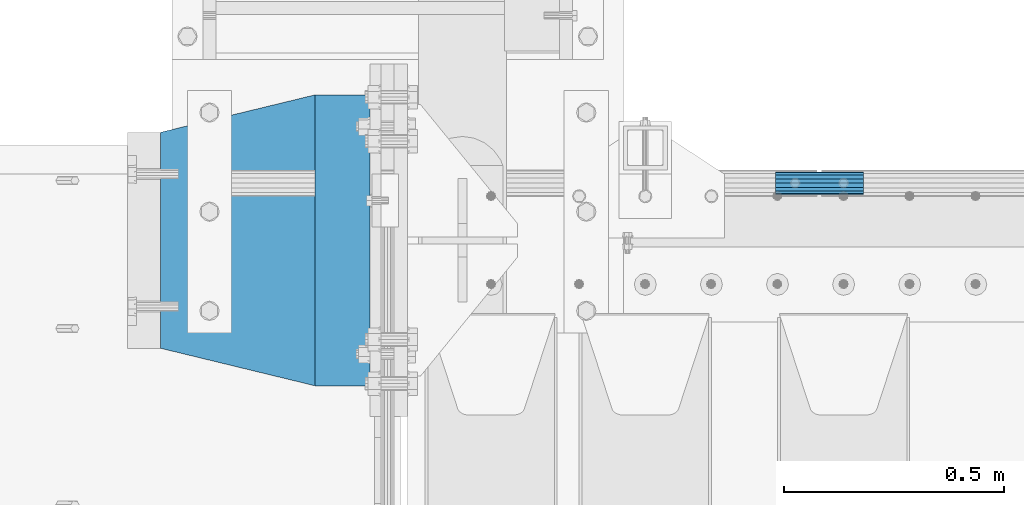
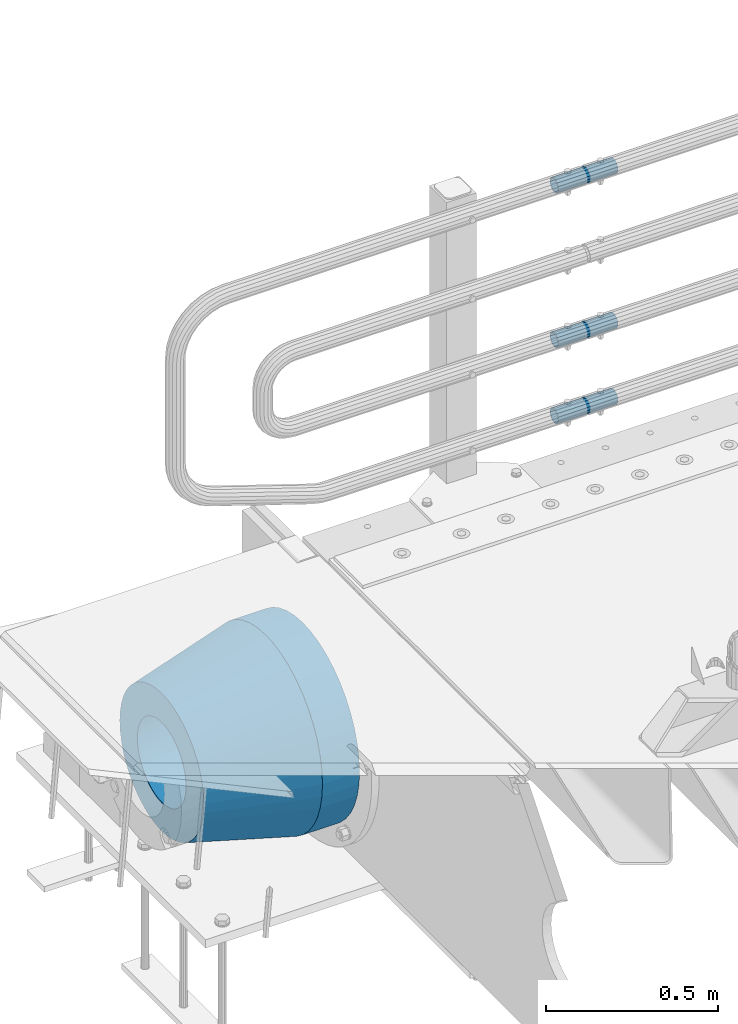
# One storey, part 151 of 240: 5 beams.
"""IFC2X3 building model written with IfcOpenShell, lengths in millimetres."""

from ifc_helpers import new_model, si_unit, frame, origin_with_axes, place, context, subcontext, project, spatial, faceted_brep, material, type_object, element, save


model = new_model("IFC2X3")

# Units and contexts
model_context = context("Model", 3, precision=1e-05, world=origin_with_axes())
body_context = subcontext(model_context, "Body", "Model", "MODEL_VIEW")
ifc_project = project(units=[si_unit("LENGTHUNIT", "METRE", prefix="MILLI"), si_unit("AREAUNIT", "SQUARE_METRE"), si_unit("VOLUMEUNIT", "CUBIC_METRE"), si_unit("MASSUNIT", "GRAM", prefix="KILO"), si_unit("TIMEUNIT", "SECOND"), si_unit("PLANEANGLEUNIT", "RADIAN"), si_unit("SOLIDANGLEUNIT", "STERADIAN"), si_unit("THERMODYNAMICTEMPERATUREUNIT", "DEGREE_CELSIUS"), si_unit("LUMINOUSINTENSITYUNIT", "LUMEN")], contexts=[model_context])

# Site, building, storey
site_placement = place(None, origin_with_axes())
site = spatial("IfcSite", under=ifc_project, at=site_placement, CompositionType="ELEMENT")
building_placement = place(site_placement, origin_with_axes())
building = spatial("IfcBuilding", under=site, at=building_placement, Name="Standard", CompositionType="ELEMENT")
storey_placement = place(building_placement, origin_with_axes())
storey = spatial("IfcBuildingStorey", under=building, at=storey_placement, Name="Undefined", CompositionType="ELEMENT", Elevation=0.0)

# Beams
ifc_material_1 = material()
beam_type_1 = type_object("IfcBeamType", PredefinedType="NOTDEFINED")
beam_1_placement = place(storey_placement, frame((43294.9975029999, 36129.8500000004, 149.849999999747), z_axis=(0.0, 0.0, 1.0), x_axis=(1.0, 0.0, 0.0)))
element("IfcBeam", 1, at=beam_1_placement, inside=storey, type_object=beam_type_1, material=ifc_material_1, context=body_context, shape_type="Brep", body=[
    faceted_brep([(0.0, -21.9000000000015, 0.0), (0.0, -20.232961761998, 8.38076716879547), (200.0, -20.232961761998, 8.38076716879547), (200.0, -21.9000000000015, 0.0), (0.0, -15.4856385079838, 15.4856385079854), (200.0, -15.4856385079838, 15.4856385079854), (0.0, -8.38076716879732, 20.2329617619972), (200.0, -8.38076716879732, 20.2329617619972), (0.0, 0.0, 21.9), (200.0, 0.0, 21.9), (0.0, 8.38076716879732, 20.2329617619972), (200.0, 8.38076716879732, 20.2329617619972), (0.0, 15.4856385079838, 15.4856385079854), (200.0, 15.4856385079838, 15.4856385079854), (0.0, 20.232961761998, 8.38076716879547), (200.0, 20.232961761998, 8.38076716879547), (0.0, 21.9000000000015, 0.0), (200.0, 21.9000000000015, 0.0), (0.0, 20.232961761998, -8.38076716879547), (200.0, 20.232961761998, -8.38076716879547), (0.0, 15.4856385079838, -15.4856385079854), (200.0, 15.4856385079838, -15.4856385079854), (0.0, 8.38076716879732, -20.2329617619972), (200.0, 8.38076716879732, -20.2329617619972), (0.0, 0.0, -21.9), (200.0, 0.0, -21.9), (0.0, -8.38076716879732, -20.2329617619972), (200.0, -8.38076716879732, -20.2329617619972), (0.0, -15.4856385079838, -15.4856385079854), (200.0, -15.4856385079838, -15.4856385079854), (0.0, -20.232961761998, -8.38076716879547), (200.0, -20.232961761998, -8.38076716879547), (0.0, -25.5, 0.0), (0.0, -23.5589280790373, -9.7584275253098), (200.0, -23.5589280790373, -9.7584275253098), (200.0, -25.5, 0.0), (0.0, -18.0312229202536, -18.031222920257), (200.0, -18.0312229202536, -18.031222920257), (0.0, -9.75842752531025, -23.5589280790378), (200.0, -9.75842752531025, -23.5589280790378), (0.0, 0.0, -25.5), (200.0, 0.0, -25.5), (0.0, 9.75842752531025, -23.5589280790378), (200.0, 9.75842752531025, -23.5589280790378), (0.0, 18.0312229202536, -18.031222920257), (200.0, 18.0312229202536, -18.031222920257), (0.0, 23.5589280790373, -9.7584275253098), (200.0, 23.5589280790373, -9.7584275253098), (0.0, 25.5, 0.0), (200.0, 25.5, 0.0), (0.0, 23.5589280790373, 9.7584275253098), (200.0, 23.5589280790373, 9.7584275253098), (0.0, 18.0312229202536, 18.031222920257), (200.0, 18.0312229202536, 18.031222920257), (0.0, 9.75842752531025, 23.5589280790378), (200.0, 9.75842752531025, 23.5589280790378), (0.0, 0.0, 25.5), (200.0, 0.0, 25.5), (0.0, -9.75842752531025, 23.5589280790378), (200.0, -9.75842752531025, 23.5589280790378), (0.0, -18.0312229202536, 18.031222920257), (200.0, -18.0312229202536, 18.031222920257), (0.0, -23.5589280790373, 9.7584275253098), (200.0, -23.5589280790373, 9.7584275253098)], [[[0, 1, 2, 3]], [[1, 4, 5, 2]], [[4, 6, 7, 5]], [[6, 8, 9, 7]], [[8, 10, 11, 9]], [[10, 12, 13, 11]], [[12, 14, 15, 13]], [[14, 16, 17, 15]], [[16, 18, 19, 17]], [[18, 20, 21, 19]], [[20, 22, 23, 21]], [[22, 24, 25, 23]], [[24, 26, 27, 25]], [[26, 28, 29, 27]], [[28, 30, 31, 29]], [[30, 0, 3, 31]], [[32, 33, 34, 35]], [[33, 36, 37, 34]], [[36, 38, 39, 37]], [[38, 40, 41, 39]], [[40, 42, 43, 41]], [[42, 44, 45, 43]], [[44, 46, 47, 45]], [[46, 48, 49, 47]], [[48, 50, 51, 49]], [[50, 52, 53, 51]], [[52, 54, 55, 53]], [[54, 56, 57, 55]], [[56, 58, 59, 57]], [[58, 60, 61, 59]], [[60, 62, 63, 61]], [[62, 32, 35, 63]], [[37, 39, 41, 43, 45, 47, 49, 51, 53, 55, 57, 59, 61, 63, 35, 34], [5, 7, 9, 11, 13, 15, 17, 19, 21, 23, 25, 27, 29, 31, 3, 2]], [[62, 60, 58, 56, 54, 52, 50, 48, 46, 44, 42, 40, 38, 36, 33, 32], [30, 28, 26, 24, 22, 20, 18, 16, 14, 12, 10, 8, 6, 4, 1, 0]]]),
])
beam_2_placement = place(storey_placement, frame((43294.9975029999, 36129.8500000004, 420.149999999747), z_axis=(0.0, 0.0, 1.0), x_axis=(1.0, 0.0, 0.0)))
element("IfcBeam", 2, at=beam_2_placement, inside=storey, type_object=beam_type_1, material=ifc_material_1, context=body_context, shape_type="Brep", body=[
    faceted_brep([(0.0, -21.9000000000015, 0.0), (0.0, -20.232961761998, 8.38076716879547), (200.0, -20.232961761998, 8.38076716879547), (200.0, -21.9000000000015, 0.0), (0.0, -15.4856385079838, 15.4856385079854), (200.0, -15.4856385079838, 15.4856385079854), (0.0, -8.38076716879732, 20.2329617619972), (200.0, -8.38076716879732, 20.2329617619972), (0.0, 0.0, 21.9), (200.0, 0.0, 21.9), (0.0, 8.38076716879732, 20.2329617619972), (200.0, 8.38076716879732, 20.2329617619972), (0.0, 15.4856385079838, 15.4856385079854), (200.0, 15.4856385079838, 15.4856385079854), (0.0, 20.232961761998, 8.38076716879547), (200.0, 20.232961761998, 8.38076716879547), (0.0, 21.9000000000015, 0.0), (200.0, 21.9000000000015, 0.0), (0.0, 20.232961761998, -8.38076716879547), (200.0, 20.232961761998, -8.38076716879547), (0.0, 15.4856385079838, -15.4856385079854), (200.0, 15.4856385079838, -15.4856385079854), (0.0, 8.38076716879732, -20.2329617619972), (200.0, 8.38076716879732, -20.2329617619972), (0.0, 0.0, -21.9), (200.0, 0.0, -21.9), (0.0, -8.38076716879732, -20.2329617619972), (200.0, -8.38076716879732, -20.2329617619972), (0.0, -15.4856385079838, -15.4856385079854), (200.0, -15.4856385079838, -15.4856385079854), (0.0, -20.232961761998, -8.38076716879547), (200.0, -20.232961761998, -8.38076716879547), (0.0, -25.5, 0.0), (0.0, -23.5589280790373, -9.7584275253098), (200.0, -23.5589280790373, -9.7584275253098), (200.0, -25.5, 0.0), (0.0, -18.0312229202536, -18.031222920257), (200.0, -18.0312229202536, -18.031222920257), (0.0, -9.75842752531025, -23.5589280790378), (200.0, -9.75842752531025, -23.5589280790378), (0.0, 0.0, -25.5), (200.0, 0.0, -25.5), (0.0, 9.75842752531025, -23.5589280790378), (200.0, 9.75842752531025, -23.5589280790378), (0.0, 18.0312229202536, -18.031222920257), (200.0, 18.0312229202536, -18.031222920257), (0.0, 23.5589280790373, -9.7584275253098), (200.0, 23.5589280790373, -9.7584275253098), (0.0, 25.5, 0.0), (200.0, 25.5, 0.0), (0.0, 23.5589280790373, 9.7584275253098), (200.0, 23.5589280790373, 9.7584275253098), (0.0, 18.0312229202536, 18.031222920257), (200.0, 18.0312229202536, 18.031222920257), (0.0, 9.75842752531025, 23.5589280790378), (200.0, 9.75842752531025, 23.5589280790378), (0.0, 0.0, 25.5), (200.0, 0.0, 25.5), (0.0, -9.75842752531025, 23.5589280790378), (200.0, -9.75842752531025, 23.5589280790378), (0.0, -18.0312229202536, 18.031222920257), (200.0, -18.0312229202536, 18.031222920257), (0.0, -23.5589280790373, 9.7584275253098), (200.0, -23.5589280790373, 9.7584275253098)], [[[0, 1, 2, 3]], [[1, 4, 5, 2]], [[4, 6, 7, 5]], [[6, 8, 9, 7]], [[8, 10, 11, 9]], [[10, 12, 13, 11]], [[12, 14, 15, 13]], [[14, 16, 17, 15]], [[16, 18, 19, 17]], [[18, 20, 21, 19]], [[20, 22, 23, 21]], [[22, 24, 25, 23]], [[24, 26, 27, 25]], [[26, 28, 29, 27]], [[28, 30, 31, 29]], [[30, 0, 3, 31]], [[32, 33, 34, 35]], [[33, 36, 37, 34]], [[36, 38, 39, 37]], [[38, 40, 41, 39]], [[40, 42, 43, 41]], [[42, 44, 45, 43]], [[44, 46, 47, 45]], [[46, 48, 49, 47]], [[48, 50, 51, 49]], [[50, 52, 53, 51]], [[52, 54, 55, 53]], [[54, 56, 57, 55]], [[56, 58, 59, 57]], [[58, 60, 61, 59]], [[60, 62, 63, 61]], [[62, 32, 35, 63]], [[37, 39, 41, 43, 45, 47, 49, 51, 53, 55, 57, 59, 61, 63, 35, 34], [5, 7, 9, 11, 13, 15, 17, 19, 21, 23, 25, 27, 29, 31, 3, 2]], [[62, 60, 58, 56, 54, 52, 50, 48, 46, 44, 42, 40, 38, 36, 33, 32], [30, 28, 26, 24, 22, 20, 18, 16, 14, 12, 10, 8, 6, 4, 1, 0]]]),
])
beam_3_placement = place(storey_placement, frame((43294.9975029999, 36129.8500000004, 969.849999999747), z_axis=(0.0, 0.0, 1.0), x_axis=(1.0, 0.0, 0.0)))
element("IfcBeam", 3, at=beam_3_placement, inside=storey, type_object=beam_type_1, material=ifc_material_1, context=body_context, shape_type="Brep", body=[
    faceted_brep([(0.0, -21.9000000000015, 0.0), (0.0, -20.232961761998, 8.38076716879547), (200.0, -20.232961761998, 8.38076716879547), (200.0, -21.9000000000015, 0.0), (0.0, -15.4856385079838, 15.4856385079854), (200.0, -15.4856385079838, 15.4856385079854), (0.0, -8.38076716879732, 20.2329617619972), (200.0, -8.38076716879732, 20.2329617619972), (0.0, 0.0, 21.9), (200.0, 0.0, 21.9), (0.0, 8.38076716879732, 20.2329617619972), (200.0, 8.38076716879732, 20.2329617619972), (0.0, 15.4856385079838, 15.4856385079854), (200.0, 15.4856385079838, 15.4856385079854), (0.0, 20.232961761998, 8.38076716879547), (200.0, 20.232961761998, 8.38076716879547), (0.0, 21.9000000000015, 0.0), (200.0, 21.9000000000015, 0.0), (0.0, 20.232961761998, -8.38076716879547), (200.0, 20.232961761998, -8.38076716879547), (0.0, 15.4856385079838, -15.4856385079854), (200.0, 15.4856385079838, -15.4856385079854), (0.0, 8.38076716879732, -20.2329617619972), (200.0, 8.38076716879732, -20.2329617619972), (0.0, 0.0, -21.9), (200.0, 0.0, -21.9), (0.0, -8.38076716879732, -20.2329617619972), (200.0, -8.38076716879732, -20.2329617619972), (0.0, -15.4856385079838, -15.4856385079854), (200.0, -15.4856385079838, -15.4856385079854), (0.0, -20.232961761998, -8.38076716879547), (200.0, -20.232961761998, -8.38076716879547), (0.0, -25.5, 0.0), (0.0, -23.5589280790373, -9.7584275253098), (200.0, -23.5589280790373, -9.7584275253098), (200.0, -25.5, 0.0), (0.0, -18.0312229202536, -18.031222920257), (200.0, -18.0312229202536, -18.031222920257), (0.0, -9.75842752531025, -23.5589280790378), (200.0, -9.75842752531025, -23.5589280790378), (0.0, 0.0, -25.5), (200.0, 0.0, -25.5), (0.0, 9.75842752531025, -23.5589280790378), (200.0, 9.75842752531025, -23.5589280790378), (0.0, 18.0312229202536, -18.031222920257), (200.0, 18.0312229202536, -18.031222920257), (0.0, 23.5589280790373, -9.7584275253098), (200.0, 23.5589280790373, -9.7584275253098), (0.0, 25.5, 0.0), (200.0, 25.5, 0.0), (0.0, 23.5589280790373, 9.7584275253098), (200.0, 23.5589280790373, 9.7584275253098), (0.0, 18.0312229202536, 18.031222920257), (200.0, 18.0312229202536, 18.031222920257), (0.0, 9.75842752531025, 23.5589280790378), (200.0, 9.75842752531025, 23.5589280790378), (0.0, 0.0, 25.5), (200.0, 0.0, 25.5), (0.0, -9.75842752531025, 23.5589280790378), (200.0, -9.75842752531025, 23.5589280790378), (0.0, -18.0312229202536, 18.031222920257), (200.0, -18.0312229202536, 18.031222920257), (0.0, -23.5589280790373, 9.7584275253098), (200.0, -23.5589280790373, 9.7584275253098)], [[[0, 1, 2, 3]], [[1, 4, 5, 2]], [[4, 6, 7, 5]], [[6, 8, 9, 7]], [[8, 10, 11, 9]], [[10, 12, 13, 11]], [[12, 14, 15, 13]], [[14, 16, 17, 15]], [[16, 18, 19, 17]], [[18, 20, 21, 19]], [[20, 22, 23, 21]], [[22, 24, 25, 23]], [[24, 26, 27, 25]], [[26, 28, 29, 27]], [[28, 30, 31, 29]], [[30, 0, 3, 31]], [[32, 33, 34, 35]], [[33, 36, 37, 34]], [[36, 38, 39, 37]], [[38, 40, 41, 39]], [[40, 42, 43, 41]], [[42, 44, 45, 43]], [[44, 46, 47, 45]], [[46, 48, 49, 47]], [[48, 50, 51, 49]], [[50, 52, 53, 51]], [[52, 54, 55, 53]], [[54, 56, 57, 55]], [[56, 58, 59, 57]], [[58, 60, 61, 59]], [[60, 62, 63, 61]], [[62, 32, 35, 63]], [[37, 39, 41, 43, 45, 47, 49, 51, 53, 55, 57, 59, 61, 63, 35, 34], [5, 7, 9, 11, 13, 15, 17, 19, 21, 23, 25, 27, 29, 31, 3, 2]], [[62, 60, 58, 56, 54, 52, 50, 48, 46, 44, 42, 40, 38, 36, 33, 32], [30, 28, 26, 24, 22, 20, 18, 16, 14, 12, 10, 8, 6, 4, 1, 0]]]),
])
ifc_material_2 = material(Name="STEEL/S355N")
beam_type_2 = type_object("IfcBeamType", PredefinedType="NOTDEFINED")
beam_4_placement = place(storey_placement, frame((42375.0, 36000.0, -515.0), z_axis=(0.0, 0.0, 1.0), x_axis=(-1.0, 0.0, 0.0)))
element("IfcBeam", 4, at=beam_4_placement, inside=storey, type_object=beam_type_2, material=ifc_material_2, context=body_context, shape_type="Brep", body=[
    faceted_brep([(0.0, -215.0, 0.0), (0.0, -212.811610004399, 30.5976902287563), (125.0, -212.811610004399, 30.5976902287563), (125.0, -215.0, 0.0), (0.0, -206.290989327113, 60.5724997209074), (125.0, -206.290989327113, 60.5724997209074), (0.0, -195.570879001221, 89.3142277954056), (125.0, -195.570879001221, 89.3142277954056), (0.0, -180.869509558703, 116.237775752953), (125.0, -180.869509558703, 116.237775752953), (0.0, -162.486158486165, 140.795057798236), (125.0, -162.486158486165, 140.795057798236), (0.0, -140.795057798234, 162.486158486165), (125.0, -140.795057798234, 162.486158486165), (0.0, -116.237775752954, 180.869509558704), (125.0, -116.237775752954, 180.869509558704), (0.0, -89.314227795403, 195.570879001222), (125.0, -89.314227795403, 195.570879001222), (0.0, -60.5724997209109, 206.290989327117), (125.0, -60.5724997209109, 206.290989327117), (0.0, -30.5976902287584, 212.811610004401), (125.0, -30.5976902287584, 212.811610004401), (0.0, 0.0, 215.0), (125.0, 0.0, 215.0), (0.0, 30.5976902287584, 212.811610004401), (125.0, 30.5976902287584, 212.811610004401), (0.0, 60.5724997209109, 206.290989327117), (125.0, 60.5724997209109, 206.290989327117), (0.0, 89.314227795403, 195.570879001221), (125.0, 89.314227795403, 195.570879001221), (0.0, 116.237775752954, 180.869509558704), (125.0, 116.237775752954, 180.869509558704), (0.0, 140.795057798234, 162.486158486165), (125.0, 140.795057798234, 162.486158486165), (0.0, 162.486158486165, 140.795057798236), (125.0, 162.486158486165, 140.795057798236), (0.0, 180.869509558703, 116.237775752953), (125.0, 180.869509558703, 116.237775752953), (0.0, 195.570879001221, 89.3142277954056), (125.0, 195.570879001221, 89.3142277954056), (0.0, 206.290989327113, 60.5724997209073), (125.0, 206.290989327113, 60.5724997209073), (0.0, 212.811610004399, 30.5976902287563), (125.0, 212.811610004399, 30.5976902287563), (0.0, 215.0, 0.0), (125.0, 215.0, 0.0), (0.0, 212.811610004399, -30.5976902287563), (125.0, 212.811610004399, -30.5976902287563), (0.0, 206.290989327113, -60.5724997209073), (125.0, 206.290989327113, -60.5724997209073), (0.0, 195.570879001221, -89.3142277954056), (125.0, 195.570879001221, -89.3142277954056), (0.0, 180.869509558703, -116.237775752954), (125.0, 180.869509558703, -116.237775752954), (0.0, 162.486158486165, -140.795057798236), (125.0, 162.486158486165, -140.795057798236), (0.0, 140.795057798234, -162.486158486166), (125.0, 140.795057798234, -162.486158486166), (0.0, 116.237775752954, -180.869509558704), (125.0, 116.237775752954, -180.869509558704), (0.0, 89.314227795403, -195.570879001221), (125.0, 89.314227795403, -195.570879001221), (0.0, 60.5724997209109, -206.290989327117), (125.0, 60.5724997209109, -206.290989327117), (0.0, 30.5976902287584, -212.811610004401), (125.0, 30.5976902287584, -212.811610004401), (0.0, 0.0, -215.0), (125.0, 0.0, -215.0), (0.0, -30.5976902287584, -212.811610004401), (125.0, -30.5976902287584, -212.811610004401), (0.0, -60.5724997209109, -206.290989327117), (125.0, -60.5724997209109, -206.290989327117), (0.0, -89.314227795403, -195.570879001221), (125.0, -89.314227795403, -195.570879001221), (0.0, -116.237775752954, -180.869509558704), (125.0, -116.237775752954, -180.869509558704), (0.0, -140.795057798234, -162.486158486166), (125.0, -140.795057798234, -162.486158486166), (0.0, -162.486158486165, -140.795057798236), (125.0, -162.486158486165, -140.795057798236), (0.0, -180.869509558703, -116.237775752953), (125.0, -180.869509558703, -116.237775752953), (0.0, -195.570879001221, -89.3142277954056), (125.0, -195.570879001221, -89.3142277954056), (0.0, -206.290989327113, -60.5724997209073), (125.0, -206.290989327113, -60.5724997209073), (0.0, -212.811610004399, -30.5976902287563), (125.0, -212.811610004399, -30.5976902287563), (0.0, -330.0, 0.0), (0.0, -326.641075820706, -46.9638966301842), (125.0, -326.641075820706, -46.9638966301842), (125.0, -330.0, 0.0), (0.0, -316.632681292787, -92.9717437576718), (125.0, -316.632681292787, -92.9717437576718), (0.0, -300.178558466992, -137.086954290623), (125.0, -300.178558466992, -137.086954290623), (0.0, -277.613665834288, -178.411469760347), (125.0, -277.613665834288, -178.411469760347), (0.0, -249.397359536903, -216.104042201944), (125.0, -249.397359536903, -216.104042201944), (0.0, -216.104042201943, -249.397359536905), (125.0, -216.104042201943, -249.397359536905), (0.0, -178.411469760344, -277.61366583429), (125.0, -178.411469760344, -277.61366583429), (0.0, -137.086954290622, -300.178558466991), (125.0, -137.086954290622, -300.178558466991), (0.0, -92.9717437576692, -316.632681292784), (125.0, -92.9717437576692, -316.632681292784), (0.0, -46.9638966301864, -326.641075820708), (125.0, -46.9638966301864, -326.641075820708), (0.0, 0.0, -330.0), (125.0, 0.0, -330.0), (0.0, 46.9638966301864, -326.641075820708), (125.0, 46.9638966301864, -326.641075820708), (0.0, 92.9717437576692, -316.632681292784), (125.0, 92.9717437576692, -316.632681292784), (0.0, 137.086954290622, -300.178558466991), (125.0, 137.086954290622, -300.178558466991), (0.0, 178.411469760344, -277.61366583429), (125.0, 178.411469760344, -277.61366583429), (0.0, 216.104042201943, -249.397359536905), (125.0, 216.104042201943, -249.397359536905), (0.0, 249.397359536903, -216.104042201944), (125.0, 249.397359536903, -216.104042201944), (0.0, 277.613665834288, -178.411469760347), (125.0, 277.613665834288, -178.411469760347), (0.0, 300.178558466992, -137.086954290623), (125.0, 300.178558466992, -137.086954290623), (0.0, 316.632681292787, -92.9717437576717), (125.0, 316.632681292787, -92.9717437576717), (0.0, 326.641075820706, -46.9638966301841), (125.0, 326.641075820706, -46.9638966301841), (0.0, 330.0, 0.0), (125.0, 330.0, 0.0), (0.0, 326.641075820706, 46.9638966301841), (125.0, 326.641075820706, 46.9638966301841), (0.0, 316.632681292787, 92.9717437576718), (125.0, 316.632681292787, 92.9717437576718), (0.0, 300.178558466992, 137.086954290622), (125.0, 300.178558466992, 137.086954290622), (0.0, 277.613665834288, 178.411469760347), (125.0, 277.613665834288, 178.411469760347), (0.0, 249.397359536903, 216.104042201944), (125.0, 249.397359536903, 216.104042201944), (0.0, 216.104042201943, 249.397359536905), (125.0, 216.104042201943, 249.397359536905), (0.0, 178.411469760344, 277.61366583429), (125.0, 178.411469760344, 277.61366583429), (0.0, 137.086954290622, 300.178558466991), (125.0, 137.086954290622, 300.178558466991), (0.0, 92.9717437576692, 316.632681292784), (125.0, 92.9717437576692, 316.632681292784), (0.0, 46.9638966301864, 326.641075820708), (125.0, 46.9638966301864, 326.641075820708), (0.0, 0.0, 330.0), (125.0, 0.0, 330.0), (0.0, -46.9638966301864, 326.641075820708), (125.0, -46.9638966301864, 326.641075820708), (0.0, -92.9717437576692, 316.632681292784), (125.0, -92.9717437576692, 316.632681292784), (0.0, -137.086954290622, 300.178558466991), (125.0, -137.086954290622, 300.178558466991), (0.0, -178.411469760344, 277.61366583429), (125.0, -178.411469760344, 277.61366583429), (0.0, -216.104042201943, 249.397359536905), (125.0, -216.104042201943, 249.397359536905), (0.0, -249.397359536903, 216.104042201944), (125.0, -249.397359536903, 216.104042201944), (0.0, -277.613665834288, 178.411469760347), (125.0, -277.613665834288, 178.411469760347), (0.0, -300.178558466992, 137.086954290623), (125.0, -300.178558466992, 137.086954290623), (0.0, -316.632681292787, 92.9717437576718), (125.0, -316.632681292787, 92.9717437576718), (0.0, -326.641075820706, 46.9638966301841), (125.0, -326.641075820706, 46.9638966301841)], [[[0, 1, 2, 3]], [[1, 4, 5, 2]], [[4, 6, 7, 5]], [[6, 8, 9, 7]], [[8, 10, 11, 9]], [[10, 12, 13, 11]], [[12, 14, 15, 13]], [[14, 16, 17, 15]], [[16, 18, 19, 17]], [[18, 20, 21, 19]], [[20, 22, 23, 21]], [[22, 24, 25, 23]], [[24, 26, 27, 25]], [[26, 28, 29, 27]], [[28, 30, 31, 29]], [[30, 32, 33, 31]], [[32, 34, 35, 33]], [[34, 36, 37, 35]], [[36, 38, 39, 37]], [[38, 40, 41, 39]], [[40, 42, 43, 41]], [[42, 44, 45, 43]], [[44, 46, 47, 45]], [[46, 48, 49, 47]], [[48, 50, 51, 49]], [[50, 52, 53, 51]], [[52, 54, 55, 53]], [[54, 56, 57, 55]], [[56, 58, 59, 57]], [[58, 60, 61, 59]], [[60, 62, 63, 61]], [[62, 64, 65, 63]], [[64, 66, 67, 65]], [[66, 68, 69, 67]], [[68, 70, 71, 69]], [[70, 72, 73, 71]], [[72, 74, 75, 73]], [[74, 76, 77, 75]], [[76, 78, 79, 77]], [[78, 80, 81, 79]], [[80, 82, 83, 81]], [[82, 84, 85, 83]], [[84, 86, 87, 85]], [[86, 0, 3, 87]], [[88, 89, 90, 91]], [[89, 92, 93, 90]], [[92, 94, 95, 93]], [[94, 96, 97, 95]], [[96, 98, 99, 97]], [[98, 100, 101, 99]], [[100, 102, 103, 101]], [[102, 104, 105, 103]], [[104, 106, 107, 105]], [[106, 108, 109, 107]], [[108, 110, 111, 109]], [[110, 112, 113, 111]], [[112, 114, 115, 113]], [[114, 116, 117, 115]], [[116, 118, 119, 117]], [[118, 120, 121, 119]], [[120, 122, 123, 121]], [[122, 124, 125, 123]], [[124, 126, 127, 125]], [[126, 128, 129, 127]], [[128, 130, 131, 129]], [[130, 132, 133, 131]], [[132, 134, 135, 133]], [[134, 136, 137, 135]], [[136, 138, 139, 137]], [[138, 140, 141, 139]], [[140, 142, 143, 141]], [[142, 144, 145, 143]], [[144, 146, 147, 145]], [[146, 148, 149, 147]], [[148, 150, 151, 149]], [[150, 152, 153, 151]], [[152, 154, 155, 153]], [[154, 156, 157, 155]], [[156, 158, 159, 157]], [[158, 160, 161, 159]], [[160, 162, 163, 161]], [[162, 164, 165, 163]], [[164, 166, 167, 165]], [[166, 168, 169, 167]], [[168, 170, 171, 169]], [[170, 172, 173, 171]], [[172, 174, 175, 173]], [[174, 88, 91, 175]], [[93, 95, 97, 99, 101, 103, 105, 107, 109, 111, 113, 115, 117, 119, 121, 123, 125, 127, 129, 131, 133, 135, 137, 139, 141, 143, 145, 147, 149, 151, 153, 155, 157, 159, 161, 163, 165, 167, 169, 171, 173, 175, 91, 90], [5, 7, 9, 11, 13, 15, 17, 19, 21, 23, 25, 27, 29, 31, 33, 35, 37, 39, 41, 43, 45, 47, 49, 51, 53, 55, 57, 59, 61, 63, 65, 67, 69, 71, 73, 75, 77, 79, 81, 83, 85, 87, 3, 2]], [[174, 172, 170, 168, 166, 164, 162, 160, 158, 156, 154, 152, 150, 148, 146, 144, 142, 140, 138, 136, 134, 132, 130, 128, 126, 124, 122, 120, 118, 116, 114, 112, 110, 108, 106, 104, 102, 100, 98, 96, 94, 92, 89, 88], [86, 84, 82, 80, 78, 76, 74, 72, 70, 68, 66, 64, 62, 60, 58, 56, 54, 52, 50, 48, 46, 44, 42, 40, 38, 36, 34, 32, 30, 28, 26, 24, 22, 20, 18, 16, 14, 12, 10, 8, 6, 4, 1, 0]]]),
])
ifc_material_3 = material(Name="SCN-500-E2")
beam_type_3 = type_object("IfcBeamType", PredefinedType="NOTDEFINED")
beam_5_placement = place(storey_placement, frame((42250.0, 36000.0, -515.0), z_axis=(0.0, 0.0, 1.0), x_axis=(-1.0, 0.0, 0.0)))
element("IfcBeam", 5, at=beam_5_placement, inside=storey, type_object=beam_type_3, material=ifc_material_3, context=body_context, shape_type="Brep", body=[
    faceted_brep([(0.0, -330.0, 0.0), (0.0, -326.641075820706, -46.9638966301842), (350.0, -242.506253260828, -34.8671353769549), (350.0, -245.0, 0.0), (0.0, -316.632681292787, -92.9717437576718), (350.0, -235.075778535553, -69.0244764261503), (0.0, -300.178558466992, -137.086954290623), (350.0, -222.859838861856, -101.776678185462), (0.0, -277.613665834288, -178.411469760347), (350.0, -206.107115543637, -132.457000276621), (0.0, -249.397359536903, -216.104042201944), (350.0, -185.158645716794, -160.440879816595), (0.0, -216.104042201943, -249.397359536905), (350.0, -160.440879816597, -185.158645716793), (0.0, -178.411469760344, -277.61366583429), (350.0, -132.45700027662, -206.107115543639), (0.0, -137.086954290622, -300.178558466991), (350.0, -101.776678185459, -222.859838861857), (0.0, -92.9717437576692, -316.632681292784), (350.0, -69.0244764261515, -235.075778535552), (0.0, -46.9638966301864, -326.641075820708), (350.0, -34.8671353769532, -242.506253260829), (0.0, 0.0, -330.0), (350.0, 0.0, -245.0), (0.0, 46.9638966301864, -326.641075820708), (350.0, 34.8671353769532, -242.506253260829), (0.0, 92.9717437576692, -316.632681292784), (350.0, 69.0244764261515, -235.075778535552), (0.0, 137.086954290622, -300.178558466991), (350.0, 101.776678185459, -222.859838861857), (0.0, 178.411469760344, -277.61366583429), (350.0, 132.45700027662, -206.107115543639), (0.0, 216.104042201943, -249.397359536905), (350.0, 160.440879816597, -185.158645716793), (0.0, 249.397359536903, -216.104042201944), (350.0, 185.158645716794, -160.440879816595), (0.0, 277.613665834288, -178.411469760347), (350.0, 206.107115543637, -132.457000276621), (0.0, 300.178558466992, -137.086954290623), (350.0, 222.859838861856, -101.776678185462), (0.0, 316.632681292787, -92.9717437576717), (350.0, 235.075778535553, -69.0244764261502), (0.0, 326.641075820706, -46.9638966301841), (350.0, 242.506253260828, -34.8671353769548), (0.0, 330.0, 0.0), (350.0, 245.0, 0.0), (0.0, 326.641075820706, 46.9638966301841), (350.0, 242.506253260828, 34.8671353769549), (0.0, 316.632681292787, 92.9717437576718), (350.0, 235.075778535553, 69.0244764261503), (0.0, 300.178558466992, 137.086954290622), (350.0, 222.859838861856, 101.776678185462), (0.0, 277.613665834288, 178.411469760347), (350.0, 206.107115543637, 132.457000276621), (0.0, 249.397359536903, 216.104042201944), (350.0, 185.158645716794, 160.440879816595), (0.0, 216.104042201943, 249.397359536905), (350.0, 160.440879816597, 185.158645716793), (0.0, 178.411469760344, 277.61366583429), (350.0, 132.45700027662, 206.107115543639), (0.0, 137.086954290622, 300.178558466991), (350.0, 101.776678185459, 222.859838861857), (0.0, 92.9717437576692, 316.632681292784), (350.0, 69.0244764261515, 235.075778535552), (0.0, 46.9638966301864, 326.641075820708), (350.0, 34.8671353769532, 242.506253260829), (0.0, 0.0, 330.0), (350.0, 0.0, 245.0), (0.0, -46.9638966301864, 326.641075820708), (350.0, -34.8671353769532, 242.506253260829), (0.0, -92.9717437576692, 316.632681292784), (350.0, -69.0244764261515, 235.075778535552), (0.0, -137.086954290622, 300.178558466991), (350.0, -101.776678185459, 222.859838861857), (0.0, -178.411469760344, 277.61366583429), (350.0, -132.45700027662, 206.107115543639), (0.0, -216.104042201943, 249.397359536905), (350.0, -160.440879816597, 185.158645716793), (0.0, -249.397359536903, 216.104042201944), (350.0, -185.158645716794, 160.440879816595), (0.0, -277.613665834288, 178.411469760347), (350.0, -206.107115543637, 132.457000276621), (0.0, -300.178558466992, 137.086954290623), (350.0, -222.859838861856, 101.776678185462), (0.0, -316.632681292787, 92.9717437576718), (350.0, -235.075778535553, 69.0244764261503), (0.0, -326.641075820706, 46.9638966301841), (350.0, -242.506253260828, 34.8671353769549), (0.0, -227.093265923133, 0.0), (0.0, -224.781783917482, 32.3187414128026), (350.0, -140.646961357605, 20.2219801595734), (350.0, -142.093265923133, 0.0), (0.0, -217.894393008413, 63.9795664499945), (350.0, -136.337490251179, 40.032299118473), (0.0, -206.571300613236, 94.3379520160985), (350.0, -129.252581008099, 59.0276759109381), (0.0, -191.043012240007, 122.775888927343), (350.0, -119.536461949356, 76.8214194436173), (0.0, -171.625639060127, 148.714462796454), (350.0, -107.386925240011, 93.0513004111044), (0.0, -148.714462796452, 171.625639060125), (350.0, -93.0513004111053, 107.386925240013), (0.0, -122.775888927346, 191.043012240005), (350.0, -76.821419443615, 119.536461949355), (0.0, -94.3379520160961, 206.571300613232), (350.0, -59.0276759109402, 129.252581008098), (0.0, -63.9795664499979, 217.894393008413), (350.0, -40.032299118473, 136.337490251181), (0.0, -32.3187414128042, 224.781783917484), (350.0, -20.2219801595711, 140.646961357605), (0.0, 0.0, 227.093265923131), (350.0, 0.0, 142.093265923131), (0.0, 32.3187414128042, 224.781783917484), (350.0, 20.2219801595711, 140.646961357605), (0.0, 63.9795664499979, 217.894393008413), (350.0, 40.032299118473, 136.337490251181), (0.0, 94.3379520160961, 206.571300613232), (350.0, 59.0276759109402, 129.252581008098), (0.0, 122.775888927346, 191.043012240005), (350.0, 76.821419443615, 119.536461949355), (0.0, 148.714462796452, 171.625639060125), (350.0, 93.0513004111053, 107.386925240013), (0.0, 171.625639060127, 148.714462796454), (350.0, 107.386925240011, 93.0513004111044), (0.0, 191.043012240007, 122.775888927343), (350.0, 119.536461949356, 76.8214194436174), (0.0, 206.571300613236, 94.3379520160985), (350.0, 129.252581008099, 59.0276759109382), (0.0, 217.894393008413, 63.9795664499945), (350.0, 136.337490251179, 40.032299118473), (0.0, 224.781783917482, 32.3187414128025), (350.0, 140.646961357605, 20.2219801595733), (0.0, 227.093265923133, 0.0), (350.0, 142.093265923133, 0.0), (0.0, 224.781783917482, -32.3187414128026), (350.0, 140.646961357605, -20.2219801595734), (0.0, 217.894393008413, -63.9795664499945), (350.0, 136.337490251179, -40.032299118473), (0.0, 206.571300613236, -94.3379520160985), (350.0, 129.252581008099, -59.0276759109381), (0.0, 191.043012240007, -122.775888927343), (350.0, 119.536461949356, -76.8214194436174), (0.0, 171.625639060127, -148.714462796454), (350.0, 107.386925240011, -93.0513004111044), (0.0, 148.714462796452, -171.625639060125), (350.0, 93.0513004111053, -107.386925240013), (0.0, 122.775888927346, -191.043012240005), (350.0, 76.821419443615, -119.536461949355), (0.0, 94.3379520160961, -206.571300613232), (350.0, 59.0276759109402, -129.252581008098), (0.0, 63.9795664499979, -217.894393008413), (350.0, 40.032299118473, -136.337490251181), (0.0, 32.3187414128042, -224.781783917484), (350.0, 20.2219801595711, -140.646961357605), (0.0, 0.0, -227.093265923131), (350.0, 0.0, -142.093265923131), (0.0, -32.3187414128042, -224.781783917484), (350.0, -20.2219801595711, -140.646961357605), (0.0, -63.9795664499979, -217.894393008413), (350.0, -40.032299118473, -136.337490251181), (0.0, -94.3379520160961, -206.571300613232), (350.0, -59.0276759109402, -129.252581008098), (0.0, -122.775888927346, -191.043012240005), (350.0, -76.821419443615, -119.536461949355), (0.0, -148.714462796452, -171.625639060125), (350.0, -93.0513004111053, -107.386925240013), (0.0, -171.625639060127, -148.714462796454), (350.0, -107.386925240011, -93.0513004111044), (0.0, -191.043012240007, -122.775888927343), (350.0, -119.536461949356, -76.8214194436174), (0.0, -206.571300613236, -94.3379520160985), (350.0, -129.252581008099, -59.0276759109381), (0.0, -217.894393008413, -63.9795664499945), (350.0, -136.337490251179, -40.032299118473), (0.0, -224.781783917482, -32.3187414128026), (350.0, -140.646961357605, -20.2219801595734)], [[[0, 1, 2, 3]], [[1, 4, 5, 2]], [[4, 6, 7, 5]], [[6, 8, 9, 7]], [[8, 10, 11, 9]], [[10, 12, 13, 11]], [[12, 14, 15, 13]], [[14, 16, 17, 15]], [[16, 18, 19, 17]], [[18, 20, 21, 19]], [[20, 22, 23, 21]], [[22, 24, 25, 23]], [[24, 26, 27, 25]], [[26, 28, 29, 27]], [[28, 30, 31, 29]], [[30, 32, 33, 31]], [[32, 34, 35, 33]], [[34, 36, 37, 35]], [[36, 38, 39, 37]], [[38, 40, 41, 39]], [[40, 42, 43, 41]], [[42, 44, 45, 43]], [[44, 46, 47, 45]], [[46, 48, 49, 47]], [[48, 50, 51, 49]], [[50, 52, 53, 51]], [[52, 54, 55, 53]], [[54, 56, 57, 55]], [[56, 58, 59, 57]], [[58, 60, 61, 59]], [[60, 62, 63, 61]], [[62, 64, 65, 63]], [[64, 66, 67, 65]], [[66, 68, 69, 67]], [[68, 70, 71, 69]], [[70, 72, 73, 71]], [[72, 74, 75, 73]], [[74, 76, 77, 75]], [[76, 78, 79, 77]], [[78, 80, 81, 79]], [[80, 82, 83, 81]], [[82, 84, 85, 83]], [[84, 86, 87, 85]], [[86, 0, 3, 87]], [[88, 89, 90, 91]], [[89, 92, 93, 90]], [[92, 94, 95, 93]], [[94, 96, 97, 95]], [[96, 98, 99, 97]], [[98, 100, 101, 99]], [[100, 102, 103, 101]], [[102, 104, 105, 103]], [[104, 106, 107, 105]], [[106, 108, 109, 107]], [[108, 110, 111, 109]], [[110, 112, 113, 111]], [[112, 114, 115, 113]], [[114, 116, 117, 115]], [[116, 118, 119, 117]], [[118, 120, 121, 119]], [[120, 122, 123, 121]], [[122, 124, 125, 123]], [[124, 126, 127, 125]], [[126, 128, 129, 127]], [[128, 130, 131, 129]], [[130, 132, 133, 131]], [[132, 134, 135, 133]], [[134, 136, 137, 135]], [[136, 138, 139, 137]], [[138, 140, 141, 139]], [[140, 142, 143, 141]], [[142, 144, 145, 143]], [[144, 146, 147, 145]], [[146, 148, 149, 147]], [[148, 150, 151, 149]], [[150, 152, 153, 151]], [[152, 154, 155, 153]], [[154, 156, 157, 155]], [[156, 158, 159, 157]], [[158, 160, 161, 159]], [[160, 162, 163, 161]], [[162, 164, 165, 163]], [[164, 166, 167, 165]], [[166, 168, 169, 167]], [[168, 170, 171, 169]], [[170, 172, 173, 171]], [[172, 174, 175, 173]], [[174, 88, 91, 175]], [[5, 7, 9, 11, 13, 15, 17, 19, 21, 23, 25, 27, 29, 31, 33, 35, 37, 39, 41, 43, 45, 47, 49, 51, 53, 55, 57, 59, 61, 63, 65, 67, 69, 71, 73, 75, 77, 79, 81, 83, 85, 87, 3, 2], [93, 95, 97, 99, 101, 103, 105, 107, 109, 111, 113, 115, 117, 119, 121, 123, 125, 127, 129, 131, 133, 135, 137, 139, 141, 143, 145, 147, 149, 151, 153, 155, 157, 159, 161, 163, 165, 167, 169, 171, 173, 175, 91, 90]], [[86, 84, 82, 80, 78, 76, 74, 72, 70, 68, 66, 64, 62, 60, 58, 56, 54, 52, 50, 48, 46, 44, 42, 40, 38, 36, 34, 32, 30, 28, 26, 24, 22, 20, 18, 16, 14, 12, 10, 8, 6, 4, 1, 0], [174, 172, 170, 168, 166, 164, 162, 160, 158, 156, 154, 152, 150, 148, 146, 144, 142, 140, 138, 136, 134, 132, 130, 128, 126, 124, 122, 120, 118, 116, 114, 112, 110, 108, 106, 104, 102, 100, 98, 96, 94, 92, 89, 88]]]),
])

save(model, "model.ifc")
